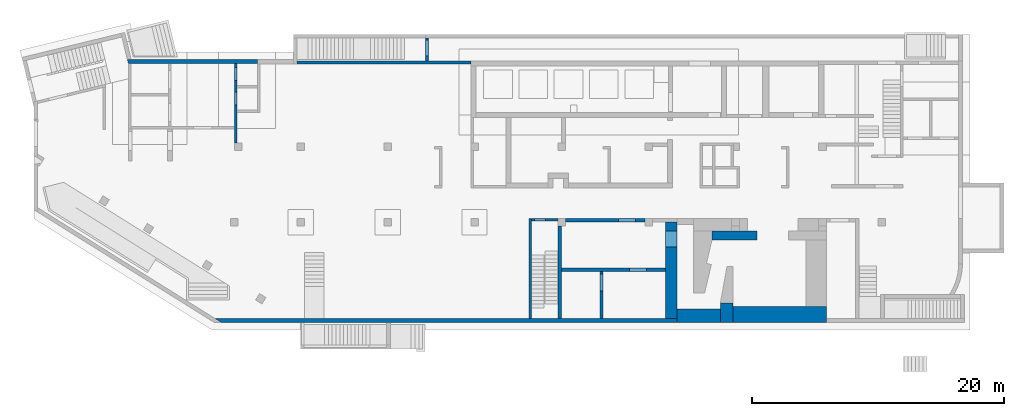
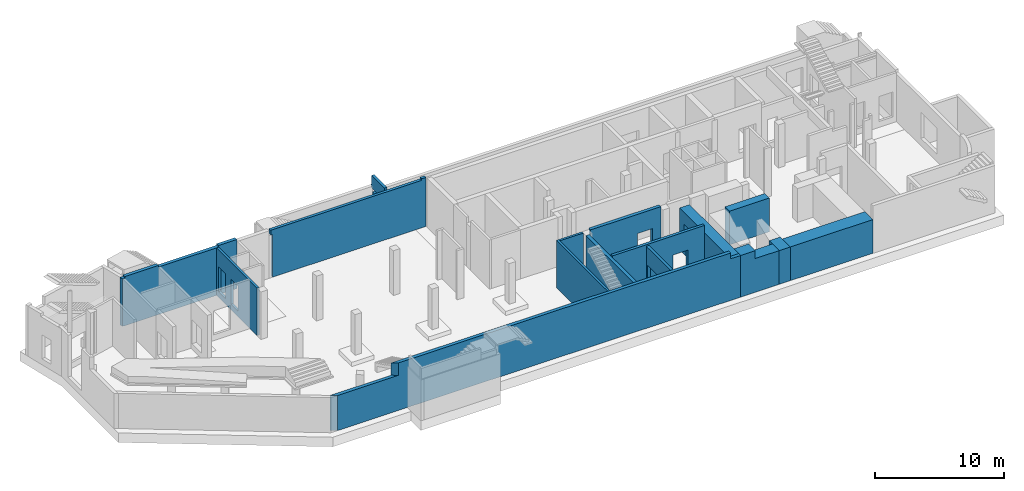
# One storey, part 6 of 9: 16 walls, 9 openings.
"""IFC4 building model written with IfcOpenShell, lengths in millimetres."""

from ifc_helpers import new_model, entity, si_unit, converted_unit, derived_unit, direction, frame, origin, place, context, subcontext, project, spatial, indexed_curve, outline, extrude, polygons, material, type_object, element, save


model = new_model("IFC4")

# Units and contexts
model_context = context("Model", 3, precision=0.01, world=origin(), true_north=direction((6.12303176911189e-17, 1.0)))
plan_context = context("Plan", 3, precision=0.01, world=origin(), true_north=direction((6.12303176911189e-17, 1.0)))
body_context = subcontext(model_context, "Body", "Model", "MODEL_VIEW")
ifc_project = project(units=[si_unit("LENGTHUNIT", "METRE", prefix="MILLI"), si_unit("AREAUNIT", "SQUARE_METRE"), si_unit("VOLUMEUNIT", "CUBIC_METRE"), converted_unit("PLANEANGLEUNIT", "DEGREE", entity("IfcRatioMeasure", 0.0174532925199433), si_unit("PLANEANGLEUNIT", "RADIAN"), dimensions=[0, 0, 0, 0, 0, 0, 0]), si_unit("MASSUNIT", "GRAM", prefix="KILO"), derived_unit("MASSDENSITYUNIT", [(si_unit("MASSUNIT", "GRAM", prefix="KILO"), 1), (si_unit("LENGTHUNIT", "METRE"), -3)]), derived_unit("MOMENTOFINERTIAUNIT", [(si_unit("LENGTHUNIT", "METRE"), 4)]), si_unit("TIMEUNIT", "SECOND"), si_unit("FREQUENCYUNIT", "HERTZ"), si_unit("THERMODYNAMICTEMPERATUREUNIT", "DEGREE_CELSIUS"), derived_unit("THERMALTRANSMITTANCEUNIT", [(si_unit("MASSUNIT", "GRAM", prefix="KILO"), 1), (si_unit("THERMODYNAMICTEMPERATUREUNIT", "KELVIN"), -1), (si_unit("TIMEUNIT", "SECOND"), -3)]), derived_unit("VOLUMETRICFLOWRATEUNIT", [(si_unit("LENGTHUNIT", "METRE"), 3), (si_unit("TIMEUNIT", "SECOND"), -1)]), derived_unit("MASSFLOWRATEUNIT", [(si_unit("MASSUNIT", "GRAM", prefix="KILO"), 1), (si_unit("TIMEUNIT", "SECOND"), -1)]), derived_unit("ROTATIONALFREQUENCYUNIT", [(si_unit("TIMEUNIT", "SECOND"), -1)]), si_unit("ELECTRICCURRENTUNIT", "AMPERE"), si_unit("ELECTRICVOLTAGEUNIT", "VOLT"), si_unit("POWERUNIT", "WATT"), si_unit("FORCEUNIT", "NEWTON", prefix="KILO"), si_unit("ILLUMINANCEUNIT", "LUX"), si_unit("LUMINOUSFLUXUNIT", "LUMEN"), si_unit("LUMINOUSINTENSITYUNIT", "CANDELA"), derived_unit("USERDEFINED", [(si_unit("MASSUNIT", "GRAM", prefix="KILO"), -1), (si_unit("LENGTHUNIT", "METRE"), -2), (si_unit("TIMEUNIT", "SECOND"), 3), (si_unit("LUMINOUSFLUXUNIT", "LUMEN"), 1)]), derived_unit("LINEARVELOCITYUNIT", [(si_unit("LENGTHUNIT", "METRE"), 1), (si_unit("TIMEUNIT", "SECOND"), -1)]), si_unit("PRESSUREUNIT", "PASCAL"), derived_unit("USERDEFINED", [(si_unit("LENGTHUNIT", "METRE"), -2), (si_unit("MASSUNIT", "GRAM", prefix="KILO"), 1), (si_unit("TIMEUNIT", "SECOND"), -2)]), derived_unit("LINEARFORCEUNIT", [(si_unit("MASSUNIT", "GRAM", prefix="KILO"), 1), (si_unit("LENGTHUNIT", "METRE"), 1), (si_unit("TIMEUNIT", "SECOND"), -2), (si_unit("LENGTHUNIT", "METRE"), -1)]), derived_unit("PLANARFORCEUNIT", [(si_unit("MASSUNIT", "GRAM", prefix="KILO"), 1), (si_unit("LENGTHUNIT", "METRE"), 1), (si_unit("TIMEUNIT", "SECOND"), -2), (si_unit("LENGTHUNIT", "METRE"), -2)])], contexts=[model_context, plan_context])

# Site, building, storey
site_placement = place(None, origin())
site = spatial("IfcSite", under=ifc_project, at=site_placement, CompositionType="ELEMENT")
building_placement = place(site_placement, origin())
building = spatial("IfcBuilding", under=site, at=building_placement, CompositionType="ELEMENT")
storey_placement = place(building_placement, frame((0.0, 0.0, -4900.0)))
storey = spatial("IfcBuildingStorey", under=building, at=storey_placement, CompositionType="ELEMENT", Elevation=-4900.0)

# Wall
ifc_material = material()
wall_type_1 = type_object("IfcWallType", PredefinedType="STANDARD")
wall_1_placement = place(storey_placement, frame((39370.0002685546, 49.9992263561803, 0.0), z_axis=(0.0, 0.0, 1.0), x_axis=(0.0, 1.0, 0.0)))
element("IfcWall", 1, at=wall_1_placement, inside=storey, type_object=wall_type_1, material=ifc_material, PredefinedType="NOTDEFINED", context=body_context, shape_type="Tessellation", body=[
    polygons([(3.8915537459161e-13, -99.9999999999945, 0.0), (7749.99999999991, -99.9999999999934, 0.0), (7949.99999999991, -99.9999999999932, 0.0), (7949.99999999991, -99.9999999999932, 4500.0), (7749.99999999991, -99.9999999999934, 4500.0), (5325.0, -99.9999999999965, 4500.0), (1.26898491714655e-13, -99.9999999999945, 4500.0), (1.91193727516747e-12, 100.000000000003, 0.0), (1.51432200112822e-12, 100.000000000003, 4500.0), (7949.99999999991, 100.000000000005, 4500.0), (7949.99999999991, 100.000000000005, 0.0)], [[[1, 2, 3, 4, 5, 6, 7]], [[8, 9, 10, 11]], [[3, 2, 1, 8, 11]], [[1, 7, 9, 8]], [[4, 3, 11, 10]], [[7, 6, 5, 4, 10, 9]]], closed=True),
])

# Wall, opening
wall_2_placement = place(storey_placement, frame((41570.0002685547, 7899.99922635609, 0.0), z_axis=(0.0, 0.0, 1.0), x_axis=(-1.0, 0.0, 0.0)))
wall_2 = element("IfcWall", 2, at=wall_2_placement, inside=storey, type_object=wall_type_1, material=ifc_material, PredefinedType="NOTDEFINED", context=body_context, shape_type="Tessellation", body=[
    polygons([(1.18902794510068e-12, -100.0, 0.0), (2100.00000000002, -100.000000000001, 0.0), (2100.00000000002, -100.000000000001, 4500.0), (1.18902794510068e-12, -100.0, 4500.0), (960.000000000008, -100.0, 2829.99999999805), (1840.00000000001, -100.000000000001, 2829.99999999804), (1840.00000000001, -100.000000000001, 550.0), (960.000000000008, -100.0, 550.0), (2100.00000000002, 99.9999999999978, 0.0), (5.09581903187964e-13, 100.0, 0.0), (5.09581903187964e-13, 100.0, 4500.0), (2100.00000000002, 99.9999999999978, 4500.0), (1840.00000000001, 99.9999999999989, 2829.99999999804), (960.000000000008, 100.000000000001, 2829.99999999805), (960.000000000008, 100.000000000001, 550.0), (1840.00000000001, 99.9999999999989, 550.0)], [[[1, 2, 3, 4], [5, 6, 7, 8]], [[9, 10, 11, 12], [13, 14, 15, 16]], [[2, 1, 10, 9]], [[4, 3, 12, 11]], [[1, 4, 11, 10]], [[3, 2, 9, 12]], [[5, 14, 13, 6]], [[6, 13, 16, 7]], [[7, 16, 15, 8]], [[14, 5, 8, 15]]], closed=True),
])
opening_1_placement = place(wall_2_placement, frame((41570.0002685547, 7899.99922635609, 0.0), z_axis=(0.0, 0.0, 1.0), x_axis=(-1.0, 0.0, 0.0)))
element("IfcOpeningElement", 3, at=opening_1_placement, cuts=wall_2, PredefinedType="OPENING", context=body_context, shape_type="SweptSolid", body=[
    extrude(outline(indexed_curve([(-439.999999999995, -1139.99999999902), (440.000000000004, -1139.99999999902), (440.000000000004, 1139.99999999902), (-439.999999999995, 1139.99999999902), (-439.999999999995, -1139.99999999902)], self_intersect=False)), frame((40170.0002685547, 8099.99922635803, 1690.0), z_axis=(0.0, -1.0, 0.0), x_axis=(-1.0, 0.0, 0.0)), (0.0, 0.0, 1.0), 400.000000001942),
])

# Wall, openings
wall_3_placement = place(storey_placement, frame((16000.0002685547, 13999.9992263563, 0.0), z_axis=(0.0, 0.0, 1.0), x_axis=(0.0, 1.0, 0.0)))
wall_3 = element("IfcWall", 4, at=wall_3_placement, inside=storey, type_object=wall_type_1, material=ifc_material, PredefinedType="NOTDEFINED", context=body_context, shape_type="Tessellation", body=[
    polygons([(0.0, -100.000000000001, 0.0), (2399.99999999961, -100.000000000001, 0.0), (2599.99999999961, -100.000000000001, 0.0), (4349.9999999998, -99.9999999999999, 0.0), (4549.9999999998, -100.000000000002, 0.0), (6300.0, -99.9999999999987, 0.0), (6300.0, -99.9999999999987, 4500.0), (2500.00063936648, -100.000000000001, 4500.0), (0.0, -100.000000000001, 4500.0), (2980.0, -100.0, 2919.99999999804), (4020.0, -100.0, 2919.99999999804), (4020.0, -100.0, 550.0), (2980.0, -100.0, 550.0), (4930.00000000001, -100.000000000001, 2919.99999999804), (5970.0, -99.9999999999992, 2919.99999999804), (5970.0, -99.9999999999992, 550.0), (4930.00000000001, -100.000000000001, 550.0), (6300.0, 99.9999999999992, 0.0), (1299.99999999955, 99.9999999999992, 0.0), (1099.99999999955, 99.9999999999989, 0.0), (0.0, 99.9999999999992, 0.0), (0.0, 99.9999999999992, 4500.0), (6300.0, 99.9999999999992, 4500.0), (4020.0, 99.9999999999996, 2919.99999999804), (2980.0, 99.9999999999978, 2919.99999999804), (2980.00000000001, 99.9999999999978, 550.0), (4020.0, 99.9999999999996, 550.0), (5970.0, 99.9999999999986, 2919.99999999804), (4930.00000000001, 99.999999999999, 2919.99999999804), (4930.00000000001, 99.999999999999, 550.0), (5970.0, 99.9999999999986, 550.0)], [[[1, 2, 3, 4, 5, 6, 7, 8, 9], [10, 11, 12, 13], [14, 15, 16, 17]], [[18, 19, 20, 21, 22, 23], [24, 25, 26, 27], [28, 29, 30, 31]], [[6, 5, 4, 3, 2, 1, 21, 20, 19, 18]], [[9, 8, 7, 23, 22]], [[1, 9, 22, 21]], [[7, 6, 18, 23]], [[24, 11, 10, 25]], [[25, 10, 13, 26]], [[26, 13, 12, 27]], [[11, 24, 27, 12]], [[28, 15, 14, 29]], [[29, 14, 17, 30]], [[30, 17, 16, 31]], [[15, 28, 31, 16]]], closed=True),
])
opening_2_placement = place(wall_3_placement, frame((-13999.9992263563, 16000.0002685547, 0.0), z_axis=(0.0, 0.0, 1.0), x_axis=(0.0, -1.0, 0.0)))
element("IfcOpeningElement", 5, at=opening_2_placement, cuts=wall_3, PredefinedType="OPENING", context=body_context, shape_type="SweptSolid", body=[
    extrude(outline(indexed_curve([(-1184.99999999902, -519.999999999999), (1184.99999999902, -519.999999999999), (1184.99999999902, 520.000000000001), (-1184.99999999902, 520.000000000001), (-1184.99999999902, -519.999999999999)], self_intersect=False)), frame((16200.0002685547, 17499.9992263564, 1735.0), z_axis=(-1.0, 0.0, 0.0), x_axis=(0.0, 0.0, -1.0)), (0.0, 0.0, 1.0), 400.000000001943),
])
opening_3_placement = place(wall_3_placement, frame((-13999.9992263563, 16000.0002685547, 0.0), z_axis=(0.0, 0.0, 1.0), x_axis=(0.0, -1.0, 0.0)))
element("IfcOpeningElement", 6, at=opening_3_placement, cuts=wall_3, PredefinedType="OPENING", context=body_context, shape_type="SweptSolid", body=[
    extrude(outline(indexed_curve([(-1184.99999999902, -519.999999999999), (1184.99999999902, -519.999999999999), (1184.99999999902, 519.999999999999), (-1184.99999999902, 519.999999999999), (-1184.99999999902, -519.999999999999)], self_intersect=False)), frame((16200.0002685547, 19449.9992263563, 1735.0), z_axis=(-1.0, 0.0, 0.0), x_axis=(0.0, 0.0, -1.0)), (0.0, 0.0, 1.0), 400.000000001943),
])

# Walls
wall_type_2 = type_object("IfcWallType", PredefinedType="STANDARD")
wall_4_placement = place(storey_placement, frame((7420.4125693099, 20449.9992263564, 0.0)))
element("IfcWall", 7, at=wall_4_placement, inside=storey, type_object=wall_type_2, material=ifc_material, PredefinedType="NOTDEFINED", context=body_context, shape_type="Tessellation", body=[
    polygons([(73.128173937497, -150.000000000005, 0.0), (79.587699244774, -150.000000000005, 0.0), (279.587699244774, -150.000000000005, 0.0), (3279.58769924477, -150.000000000005, 0.0), (3479.58769924477, -150.000000000001, 0.0), (8479.58769924478, -150.000000000001, 0.0), (8679.58769924478, -150.000000000001, 0.0), (10304.5876992448, -150.000000000005, 0.0), (10304.5876992448, -150.000000000005, 4500.0), (10304.5876992448, -150.000000000005, 4650.0), (8679.58769924479, -150.000000000001, 4650.0), (8679.58769924479, -150.000000000001, 4500.0), (8479.58769924478, -150.000000000001, 4500.0), (3479.58769924477, -150.000000000001, 4500.0), (3279.58769924479, -150.000000000005, 4500.0), (3279.58769924479, -150.000000000005, 4650.0), (279.587699244795, -150.000000000005, 4650.0), (279.587699244795, -150.000000000005, 4500.0), (79.587699244774, -150.000000000005, 4500.0), (73.1281739374959, -150.000000000005, 4500.0), (10304.5876992448, 149.999999999996, 0.0), (308.784277163578, 149.999999999996, 0.0), (2.77954970644349e-12, 150.000000000001, 0.0), (6.13815447846702e-13, 150.000000000001, 1670.0), (6.13815447846702e-13, 150.000000000001, 1870.0), (-4.69051681451691e-13, 150.000000000001, 4500.0), (279.587699244792, 149.999999999996, 4500.0), (279.587699244792, 149.999999999996, 4650.0), (3279.58769924479, 149.999999999996, 4650.0), (3279.58769924479, 149.999999999992, 4500.0), (8679.58769924478, 150.000000000001, 4500.0), (8679.58769924478, 150.000000000001, 4650.0), (10304.5876992448, 149.999999999996, 4650.0), (10304.5876992448, 149.999999999996, 4500.0), (10304.5876992448, 50.0006393664798, 4650.0)], [[[1, 2, 3, 4, 5, 6, 7, 8, 9, 10, 11, 12, 13, 14, 15, 16, 17, 18, 19, 20]], [[21, 22, 23, 24, 25, 26, 27, 28, 29, 30, 31, 32, 33, 34]], [[8, 7, 6, 5, 4, 3, 2, 1, 23, 22, 21]], [[11, 10, 35, 33, 32]], [[23, 1, 20, 26, 25, 24]], [[8, 21, 34, 33, 35, 10, 9]], [[12, 31, 30, 15, 14, 13]], [[27, 18, 17, 28]], [[15, 30, 29, 16]], [[31, 12, 11, 32]], [[18, 27, 26, 20, 19]], [[17, 16, 29, 28]]], closed=True),
])
wall_5_placement = place(storey_placement, frame((14391.9394845148, -100.000773643646, 0.0)))
element("IfcWall", 8, at=wall_5_placement, inside=storey, type_object=wall_type_2, material=ifc_material, PredefinedType="NOTDEFINED", context=body_context, shape_type="Tessellation", body=[
    polygons([(480.109728548428, -150.0, 0.0), (6748.06078403981, -150.0, 0.0), (7048.06078403981, -150.0, 0.0), (13598.0607840398, -150.0, 0.0), (13898.0607840398, -150.0, 0.0), (36628.0607840398, -150.0, 0.0), (36628.0607840398, -150.000000000014, 3950.0), (35728.0607840398, -150.0, 3950.0), (35728.0607840398, -150.0, 4500.0), (27178.0607840398, -150.0, 4500.0), (25078.0607840398, -150.000000000001, 4500.0), (5952.71829370465, -150.000000000001, 4500.0), (5952.71829370465, -150.000000000002, 3580.0), (5952.71829370465, -150.000000000001, 3330.0), (480.109728548424, -150.0, 3330.0), (-2.51150603102073e-12, 150.0, 0.0), (6.15143100336641e-12, 150.000000000001, 3330.0), (5472.60856515624, 149.999999999999, 3330.0), (5472.60856515624, 149.999999999999, 4500.0), (6793.58304640091, 150.0, 4500.0), (24878.0607840398, 150.0, 4500.0), (25078.0607840398, 150.0, 4500.0), (27178.0607840398, 150.0, 4500.0), (27478.0607840398, 150.0, 4500.0), (30508.0607840398, 150.0, 4500.0), (30758.0607840398, 150.0, 4500.0), (35728.0607840398, 150.0, 4500.0), (35728.0607840398, 150.0, 3950.0), (36628.0607840398, 150.0, 3950.0), (36628.0607840398, 150.0, 0.0), (35728.0607840398, 150.0, 0.0), (30758.0607840398, 150.0, 0.0), (30508.0607840398, 150.0, 0.0), (27478.0607840398, 150.0, 0.0), (27178.0607840398, 150.0, 0.0), (25078.0607840398, 150.0, 0.0), (24878.0607840398, 150.0, 0.0)], [[[1, 2, 3, 4, 5, 6, 7, 8, 9, 10, 11, 12, 13, 14, 15]], [[16, 17, 18, 19, 20, 21, 22, 23, 24, 25, 26, 27, 28, 29, 30, 31, 32, 33, 34, 35, 36, 37]], [[6, 5, 4, 3, 2, 1, 16, 37, 36, 35, 34, 33, 32, 31, 30]], [[1, 15, 17, 16]], [[7, 6, 30, 29]], [[11, 10, 23, 22]], [[12, 19, 18, 14, 13]], [[27, 9, 8, 28]], [[10, 9, 27, 26, 25, 24, 23]], [[12, 11, 22, 21, 20, 19]], [[15, 14, 18, 17]], [[8, 7, 29, 28]]], closed=True),
])
wall_6_placement = place(storey_placement, frame((41720.0002685546, 49.9992263561641, 0.0), z_axis=(0.0, 0.0, 1.0), x_axis=(0.0, 1.0, 0.0)))
element("IfcWall", 9, at=wall_6_placement, inside=storey, type_object=wall_type_2, material=ifc_material, PredefinedType="NOTDEFINED", context=body_context, shape_type="Tessellation", body=[
    polygons([(3.38395977905748e-14, -150.000000000001, 0.0), (3749.99999999999, -150.000000000005, 0.0), (3999.99999999999, -150.000000000004, 0.0), (7349.99999999992, -150.000000000001, 0.0), (7349.99999999992, -150.000000000001, 4500.0), (8.45989944764369e-15, -150.000000000001, 4500.0), (1.81887838124339e-12, 150.000000000001, 0.0), (1.75965908510989e-12, 150.000000000001, 4500.0), (5325.00000000001, 149.999999999998, 4500.0), (7349.99999999992, 150.000000000001, 4500.0), (7349.99999999992, 150.000000000001, 0.0)], [[[1, 2, 3, 4, 5, 6]], [[7, 8, 9, 10, 11]], [[4, 3, 2, 1, 7, 11]], [[5, 4, 11, 10]], [[1, 6, 8, 7]], [[6, 5, 10, 9, 8]]], closed=True),
])

# Wall, opening
wall_7_placement = place(storey_placement, frame((42170.0002685547, 7849.99922635609, 0.0)))
wall_7 = element("IfcWall", 10, at=wall_7_placement, inside=storey, type_object=wall_type_2, material=ifc_material, PredefinedType="NOTDEFINED", context=body_context, shape_type="Tessellation", body=[
    polygons([(8.42232516012628e-13, -149.999999999999, 0.0), (6299.99999999999, -149.999999999999, 0.0), (6299.99999999999, -149.999999999999, 4650.0), (8.42232516012628e-13, -149.999999999999, 4650.0), (4199.99999999998, -149.999999999998, 2829.99999999805), (5549.99999999999, -149.999999999998, 2829.99999999804), (5549.99999999999, -149.999999999998, 550.0), (4199.99999999998, -149.999999999998, 550.0), (6299.99999999999, 150.000000000001, 0.0), (-1.37504410495438e-13, 149.999999999999, 0.0), (-1.37504410495442e-13, 150.000000000001, 4500.0), (-1.37504410495438e-13, 149.999999999999, 4650.0), (6299.99999999999, 150.000000000001, 4650.0), (6299.99999999999, 150.000000000001, 4500.0), (5549.99999999999, 150.000000000001, 2829.99999999804), (4199.99999999998, 150.000000000001, 2829.99999999805), (4199.99999999998, 150.000000000001, 550.0), (5549.99999999999, 150.000000000001, 550.0)], [[[1, 2, 3, 4], [5, 6, 7, 8]], [[9, 10, 11, 12, 13, 14], [15, 16, 17, 18]], [[2, 1, 10, 9]], [[3, 2, 9, 14, 13]], [[4, 3, 13, 12]], [[1, 4, 12, 11, 10]], [[5, 16, 15, 6]], [[6, 15, 18, 7]], [[7, 18, 17, 8]], [[16, 5, 8, 17]]], closed=True),
])
opening_4_placement = place(wall_7_placement, frame((-42170.0002685547, -7849.99922635609, 0.0)))
element("IfcOpeningElement", 11, at=opening_4_placement, cuts=wall_7, PredefinedType="OPENING", context=body_context, shape_type="SweptSolid", body=[
    extrude(outline(indexed_curve([(-675.000000000003, -1139.99999999902), (674.999999999994, -1139.99999999902), (674.999999999994, 1139.99999999902), (-675.000000000003, 1139.99999999902), (-675.000000000003, -1139.99999999902)], self_intersect=False)), frame((47045.0002685547, 7599.99922635413, 1690.0), z_axis=(0.0, 1.0, 0.0), x_axis=(1.0, 0.0, 0.0)), (0.0, 0.0, 1.0), 500.000000001943),
])

# Wall
wall_type_3 = type_object("IfcWallType", PredefinedType="STANDARD")
wall_8_placement = place(storey_placement, frame((53803.2375853265, 6649.99922635606, 0.0)))
element("IfcWall", 12, at=wall_8_placement, inside=storey, type_object=wall_type_3, material=ifc_material, PredefinedType="NOTDEFINED", context=body_context, shape_type="Tessellation", body=[
    polygons([(1.11788315284292e-13, -349.999999999999, 0.0), (3566.7626832281, -349.999999999999, 0.0), (3566.7626832281, -349.999999999999, 3200.0), (1.11788315284292e-13, -349.999999999999, 3200.0), (-1.8008881144258e-12, 350.000000000002, 0.0), (-1.80088811442579e-12, 350.000000000001, 3000.0), (-1.8008881144258e-12, 350.000000000002, 3200.0), (2166.76268322811, 349.999999999999, 3200.0), (2816.76268322809, 350.000000000001, 3200.0), (3566.76268322809, 350.000000000001, 3200.0), (3566.76268322809, 350.000000000001, 0.0), (2816.76268322809, 350.000000000001, 0.0), (2166.76268322811, 349.999999999999, 0.0), (1566.76268322811, 350.000000000001, 0.0)], [[[1, 2, 3, 4]], [[5, 6, 7, 8, 9, 10, 11, 12, 13, 14]], [[2, 1, 5, 14, 13, 12, 11]], [[3, 2, 11, 10]], [[1, 4, 7, 6, 5]], [[4, 3, 10, 9, 8, 7]]], closed=True),
])

# Wall, opening
wall_type_4 = type_object("IfcWallType", PredefinedType="STANDARD")
wall_9_placement = place(storey_placement, frame((41870.0002685546, 3924.99922635616, 0.0)))
wall_9 = element("IfcWall", 13, at=wall_9_placement, inside=storey, type_object=wall_type_4, material=ifc_material, PredefinedType="NOTDEFINED", context=body_context, shape_type="Tessellation", body=[
    polygons([(-3.3681141022685e-12, -125.0, 0.0), (3029.99999999998, -125.0, 0.0), (3279.99999999999, -125.0, 0.0), (8249.99999999999, -125.0, 0.0), (8249.99999999999, -125.0, 4650.0), (-3.3681141022685e-12, -125.0, 4650.0), (5399.99999999998, -125.000000000001, 2829.99999999804), (6749.99999999999, -125.000000000001, 2829.99999999805), (6749.99999999999, -125.000000000001, 550.0), (5399.99999999998, -125.000000000001, 550.0), (8249.99999999999, 124.999999999999, 0.0), (-4.15963078556216e-12, 124.999999999999, 0.0), (-4.15963078556216e-12, 124.999999999999, 4650.0), (8249.99999999999, 124.999999999999, 4650.0), (6749.99999999999, 125.0, 2829.99999999805), (5399.99999999998, 125.0, 2829.99999999804), (5399.99999999998, 125.0, 550.0), (6749.99999999999, 125.0, 550.0)], [[[1, 2, 3, 4, 5, 6], [7, 8, 9, 10]], [[11, 12, 13, 14], [15, 16, 17, 18]], [[4, 3, 2, 1, 12, 11]], [[6, 5, 14, 13]], [[1, 6, 13, 12]], [[5, 4, 11, 14]], [[15, 8, 7, 16]], [[16, 7, 10, 17]], [[17, 10, 9, 18]], [[8, 15, 18, 9]]], closed=True),
])
opening_5_placement = place(wall_9_placement, frame((-41870.0002685546, -3924.99922635616, 0.0)))
element("IfcOpeningElement", 14, at=opening_5_placement, cuts=wall_9, PredefinedType="OPENING", context=body_context, shape_type="SweptSolid", body=[
    extrude(outline(indexed_curve([(-1139.99999999902, -674.999999999994), (1139.99999999902, -674.999999999994), (1139.99999999902, 675.000000000003), (-1139.99999999902, 675.000000000003), (-1139.99999999902, -674.999999999994)], self_intersect=False)), frame((47945.0002685546, 3699.99922635614, 1690.0), z_axis=(0.0, 1.0, 0.0), x_axis=(0.0, 0.0, -1.0)), (0.0, 0.0, 1.0), 450.000000000965),
])

wall_10_placement = place(storey_placement, frame((45025.0002685546, 3799.99922635615, 0.0), z_axis=(0.0, 0.0, 1.0), x_axis=(0.0, -1.0, 0.0)))
wall_10 = element("IfcWall", 15, at=wall_10_placement, inside=storey, type_object=wall_type_4, material=ifc_material, PredefinedType="NOTDEFINED", context=body_context, shape_type="Tessellation", body=[
    polygons([(0.0, -125.000000000007, 0.0), (3750.00000000001, -125.000000000006, 0.0), (3750.00000000001, -125.000000000006, 4500.0), (0.0, -125.000000000007, 4500.0), (200.0, -125.000000000007, 2829.99999999804), (1550.0, -125.000000000003, 2829.99999999805), (1550.0, -125.000000000003, 550.0), (200.000000000001, -125.000000000007, 550.0), (3750.00000000001, 124.999999999997, 0.0), (-5.41433564649196e-13, 124.999999999996, 0.0), (-5.41433564649196e-13, 124.999999999996, 4500.0), (3750.00000000001, 124.999999999997, 4500.0), (1550.0, 125.0, 2829.99999999805), (200.000000000001, 124.999999999997, 2829.99999999804), (200.000000000001, 124.999999999997, 550.0), (1550.0, 125.0, 550.0)], [[[1, 2, 3, 4], [5, 6, 7, 8]], [[9, 10, 11, 12], [13, 14, 15, 16]], [[2, 1, 10, 9]], [[3, 2, 9, 12]], [[1, 4, 11, 10]], [[4, 3, 12, 11]], [[13, 6, 5, 14]], [[14, 5, 8, 15]], [[15, 8, 7, 16]], [[6, 13, 16, 7]]], closed=True),
])
opening_6_placement = place(wall_10_placement, frame((3799.99922635615, -45025.0002685546, 0.0), z_axis=(0.0, 0.0, 1.0), x_axis=(0.0, 1.0, 0.0)))
element("IfcOpeningElement", 16, at=opening_6_placement, cuts=wall_10, PredefinedType="OPENING", context=body_context, shape_type="SweptSolid", body=[
    extrude(outline(indexed_curve([(-1139.99999999902, -675.0), (1139.99999999902, -675.0), (1139.99999999902, 675.0), (-1139.99999999902, 675.0), (-1139.99999999902, -675.0)], self_intersect=False)), frame((44800.0002685546, 2924.99922635615, 1690.0), z_axis=(1.0, 0.0, 0.0), x_axis=(0.0, 0.0, -1.0)), (0.0, 0.0, 1.0), 450.000000000963),
])

# Wall
wall_11_placement = place(storey_placement, frame((34670.0002685547, 20374.9992263561, 0.0), z_axis=(0.0, 0.0, 1.0), x_axis=(-1.0, 0.0, 0.0)))
element("IfcWall", 17, at=wall_11_placement, inside=storey, type_object=wall_type_4, material=ifc_material, PredefinedType="NOTDEFINED", context=body_context, shape_type="Tessellation", body=[
    polygons([(-5.34363569620451e-13, -124.999999999998, 0.0), (3360.0, -124.999999999998, 0.0), (3610.0, -125.000000000002, 0.0), (13780.0, -124.999999999998, 0.0), (13780.0, -124.999999999998, 4035.0), (13930.0, -124.999999999998, 4035.0), (13930.0, -124.999999999998, 4500.0), (399.999999999952, -125.000213122213, 4500.0), (399.999999999952, -124.999999999998, 4650.0), (-5.34363569620451e-13, -124.999999999998, 4650.0), (-5.34363569620451e-13, -124.999999999998, 4450.0), (13780.0, 125.000000000002, 0.0), (-1.32018877230434e-12, 125.000000000002, 0.0), (-1.32018877230434e-12, 125.000000000002, 4650.0), (399.999999999951, 125.000000000002, 4650.0), (399.999999999951, 125.000000000002, 4500.0), (13930.0, 125.000000000002, 4500.0), (13930.0, 125.000000000002, 4035.0), (13780.0, 125.000000000002, 4035.0)], [[[1, 2, 3, 4, 5, 6, 7, 8, 9, 10, 11]], [[12, 13, 14, 15, 16, 17, 18, 19]], [[4, 3, 2, 1, 13, 12]], [[14, 10, 9, 15]], [[1, 11, 10, 14, 13]], [[6, 18, 17, 7]], [[18, 6, 5, 19]], [[4, 12, 19, 5]], [[16, 8, 7, 17]], [[8, 16, 15, 9]]], closed=True),
])

# Wall, openings
wall_12_placement = place(storey_placement, frame((31185.0002685547, 20499.9992263561, 0.0), z_axis=(0.0, 0.0, 1.0), x_axis=(0.0, 1.0, 0.0)))
wall_12 = element("IfcWall", 18, at=wall_12_placement, inside=storey, type_object=wall_type_4, material=ifc_material, PredefinedType="NOTDEFINED", context=body_context, shape_type="Tessellation", body=[
    polygons([(0.0, -124.999999999996, 0.0), (1799.99999999994, -124.999999999992, 0.0), (1799.99999999994, -124.999999999992, 3300.0), (0.0, -124.999999999996, 3300.0), (399.999999999939, -124.999999999995, 2829.99999999805), (1649.99999999994, -124.999999999992, 2829.99999999804), (1649.99999999994, -124.999999999992, 550.0), (399.999999999939, -124.999999999995, 550.0), (1799.99999999994, 125.000000000004, 0.0), (4.33146851719357e-12, 125.000000000004, 0.0), (4.33146851719357e-12, 125.000000000004, 3300.0), (1799.99999999994, 125.000000000008, 3300.0), (1649.99999999994, 125.000000000003, 2829.99999999804), (399.999999999939, 125.000000000005, 2829.99999999805), (399.999999999939, 125.000000000005, 550.0), (1649.99999999994, 125.000000000003, 550.0)], [[[1, 2, 3, 4], [5, 6, 7, 8]], [[9, 10, 11, 12], [13, 14, 15, 16]], [[2, 1, 10, 9]], [[10, 1, 4, 11]], [[2, 9, 12, 3]], [[4, 3, 12, 11]], [[5, 14, 13, 6]], [[16, 7, 6, 13]], [[7, 16, 15, 8]], [[8, 15, 14, 5]]], closed=True),
    polygons([(0.0, -124.999999999996, 4725.0), (1999.99999999993, -124.999999999991, 4725.0), (1999.99999999993, 125.000000000004, 4725.0), (1799.99999999993, 125.000000000004, 4725.0), (4.33146851719357e-12, 125.000000000004, 4725.0), (2099.99999999994, -125.0, 3550.0), (0.0, -124.999999999996, 3550.0), (4.33146851719357e-12, 125.000000000004, 3550.0), (2099.99999999994, 125.000000000009, 3550.0), (1999.99999999993, -124.999999999991, 3825.0), (2099.99999999994, -125.0, 3825.0), (2099.99999999994, 125.000000000004, 3825.0), (1999.99999999993, 125.000000000004, 3825.0)], [[[1, 2, 3, 4, 5]], [[6, 7, 8, 9]], [[10, 11, 12, 13]], [[12, 11, 6, 9]], [[3, 2, 10, 13]], [[1, 5, 8, 7]], [[5, 4, 3, 13, 12, 9, 8]], [[2, 1, 7, 6, 11, 10]]], closed=True),
])
opening_7_placement = place(storey_placement, frame((31185.0002685547, 20499.9992263561, 0.0), z_axis=(0.0, 0.0, 1.0), x_axis=(0.0, 1.0, 0.0)))
element("IfcOpeningElement", 19, at=opening_7_placement, cuts=wall_12, PredefinedType="OPENING", context=body_context, shape_type="SweptSolid", body=[
    extrude(outline(indexed_curve([(-899.999999999968, -125.0), (899.999999999969, -125.0), (899.999999999968, 125.000000000004), (-899.999999999965, 125.0), (-899.999999999968, -125.0)], self_intersect=False)), frame((900.0, 0.0, 3300.0)), (0.0, 0.0, 1.0), 250.0),
])
opening_8_placement = place(wall_12_placement, frame((-20499.9992263561, 31185.0002685547, 0.0), z_axis=(0.0, 0.0, 1.0), x_axis=(0.0, -1.0, 0.0)))
element("IfcOpeningElement", 20, at=opening_8_placement, cuts=wall_12, PredefinedType="OPENING", context=body_context, shape_type="SweptSolid", body=[
    extrude(outline(indexed_curve([(-625.000000000001, -1139.99999999902), (625.000000000001, -1139.99999999902), (625.000000000001, 1139.99999999902), (-625.000000000001, 1139.99999999902), (-625.000000000001, -1139.99999999902)], self_intersect=False)), frame((31410.0002685556, 21524.9992263561, 1690.0), z_axis=(-1.0, 0.0, 0.0), x_axis=(0.0, 1.0, 0.0)), (0.0, 0.0, 1.0), 450.000000000968),
])

# Wall, opening
wall_type_5 = type_object("IfcWallType", PredefinedType="STANDARD")
wall_13_placement = place(storey_placement, frame((50570.0002685546, 49.9992263561014, 0.0), z_axis=(0.0, 0.0, 1.0), x_axis=(0.0, 1.0, 0.0)))
wall_13 = element("IfcWall", 21, at=wall_13_placement, inside=storey, type_object=wall_type_5, material=ifc_material, PredefinedType="NOTDEFINED", context=body_context, shape_type="Tessellation", body=[
    polygons([(0.0, -450.000000000002, 0.0), (750.0, -450.0, 0.0), (7449.99999999995, -449.999999999999, 0.0), (7649.99999999996, -449.999999999998, 0.0), (7649.99999999996, -449.999999999998, 3950.0), (7449.99999999996, -449.999999999999, 3950.0), (750.0, -450.0, 3950.0), (2.96096480667529e-13, -450.000000000002, 3950.0), (5699.99999999996, -450.000000000001, 2829.99999999805), (6949.99999999996, -449.999999999999, 2829.99999999804), (6949.99999999996, -449.999999999999, 550.0), (5699.99999999996, -450.000000000001, 550.0), (7649.99999999996, 450.000000000005, 0.0), (4000.00000000003, 449.999999999999, 0.0), (3750.00000000003, 449.999999999999, 0.0), (4.46682690835587e-12, 450.000000000002, 0.0), (4.83906248405219e-12, 450.000000000002, 3950.0), (7649.99999999996, 450.000000000005, 3950.0), (6949.99999999996, 450.000000000004, 2829.99999999804), (5699.99999999996, 450.000000000002, 2829.99999999805), (5699.99999999996, 450.000000000002, 550.0), (6949.99999999996, 450.000000000004, 550.0), (7649.99999999996, 3.26519321837455e-12, 3950.0)], [[[1, 2, 3, 4, 5, 6, 7, 8], [9, 10, 11, 12]], [[13, 14, 15, 16, 17, 18], [19, 20, 21, 22]], [[4, 3, 2, 1, 16, 15, 14, 13]], [[5, 4, 13, 18, 23]], [[1, 8, 17, 16]], [[8, 7, 6, 5, 23, 18, 17]], [[9, 20, 19, 10]], [[10, 19, 22, 11]], [[11, 22, 21, 12]], [[20, 9, 12, 21]]], closed=True),
])
opening_9_placement = place(wall_13_placement, frame((-49.9992263561014, 50570.0002685546, 0.0), z_axis=(0.0, 0.0, 1.0), x_axis=(0.0, -1.0, 0.0)))
element("IfcOpeningElement", 22, at=opening_9_placement, cuts=wall_13, PredefinedType="OPENING", context=body_context, shape_type="SweptSolid", body=[
    extrude(outline(indexed_curve([(-625.0, -1139.99999999902), (625.0, -1139.99999999902), (625.0, 1139.99999999902), (-625.0, 1139.99999999902), (-625.0, -1139.99999999902)], self_intersect=False)), frame((51120.0002685566, 6374.99922635606, 1690.0), z_axis=(-1.0, 0.0, 0.0), x_axis=(0.0, 1.0, 0.0)), (0.0, 0.0, 1.0), 1100.00000000194),
])

# Walls
wall_type_6 = type_object("IfcWallType", PredefinedType="STANDARD")
wall_14_placement = place(storey_placement, frame((51020.0002685546, 274.999226356101, 0.0)))
element("IfcWall", 23, at=wall_14_placement, inside=storey, type_object=wall_type_6, material=ifc_material, PredefinedType="NOTDEFINED", context=body_context, shape_type="Tessellation", body=[
    polygons([(1.70390577124004e-12, -525.0, 0.0), (3450.0, -525.0, 0.0), (3450.0, -525.000000000011, 3200.0), (1300.0, -525.0, 3200.0), (1300.0, -525.0, 3950.0), (1.70390577124004e-12, -525.0, 3950.0), (-5.45247632200275e-12, 525.0, 0.0), (-5.45247632200275e-12, 525.0, 3950.0), (1299.99999999999, 525.0, 3950.0), (1299.99999999999, 525.0, 3200.0), (3449.99999999999, 525.0, 3200.0), (3449.99999999999, 525.0, 0.0), (-3.40774826829325e-13, -225.0, 0.0), (-3.40774826829325e-13, -225.0, 3950.0)], [[[1, 2, 3, 4, 5, 6]], [[7, 8, 9, 10, 11, 12]], [[2, 1, 13, 7, 12]], [[1, 6, 14, 8, 7, 13]], [[3, 2, 12, 11]], [[6, 5, 9, 8, 14]], [[9, 5, 4, 10]], [[4, 3, 11, 10]]], closed=True),
])
wall_type_7 = type_object("IfcWallType", PredefinedType="STANDARD")
wall_15_placement = place(storey_placement, frame((55470.0002685546, 374.99922635607, 0.0)))
element("IfcWall", 24, at=wall_15_placement, inside=storey, type_object=wall_type_7, material=ifc_material, PredefinedType="NOTDEFINED", context=body_context, shape_type="Tessellation", body=[
    polygons([(1.03859299249257e-11, -625.0, 0.0), (7400.00000000002, -625.0, 0.0), (7400.00000000002, -625.0, 3200.0), (1.03859299249257e-11, -625.0, 3200.0), (1.77099213181024e-12, 625.0, 0.0), (1.77099213181024e-12, 625.0, 3200.0), (5800.00000000001, 625.0, 3200.0), (7400.00000000002, 625.0, 3200.0), (7400.00000000001, 625.0, 0.0), (5800.00000000001, 625.0, 0.0), (7400.00000000002, -325.0, 0.0)], [[[1, 2, 3, 4]], [[5, 6, 7, 8, 9, 10]], [[2, 1, 5, 10, 9, 11]], [[1, 4, 6, 5]], [[3, 2, 11, 9, 8]], [[4, 3, 8, 7, 6]]], closed=True),
])
wall_type_8 = type_object("IfcWallType", PredefinedType="STANDARD")
wall_16_placement = place(storey_placement, frame((54970.0002685546, -250.000773643959, 0.0), z_axis=(0.0, 0.0, 1.0), x_axis=(0.0, 1.0, 0.0)))
element("IfcWall", 25, at=wall_16_placement, inside=storey, type_object=wall_type_8, material=ifc_material, PredefinedType="NOTDEFINED", context=body_context, shape_type="Tessellation", body=[
    polygons([(2.97788460557058e-11, -499.999999999999, 0.0), (1250.00000000003, -499.999999999999, 0.0), (1550.00000000004, -499.999999999999, 0.0), (1550.00000000004, -499.999999999999, 3200.0), (1250.00000000003, -499.999999999999, 3200.0), (9.91500215263841e-12, -499.999999999999, 3200.0), (3.66821240049831e-11, 499.999999999999, 0.0), (3.65806052116113e-11, 499.999999999999, 3200.0), (1050.00000000004, 499.999999999999, 3200.0), (1550.00000000004, 499.999999999999, 3200.0), (1550.00000000004, 499.999999999999, 0.0), (1050.00000000004, 499.999999999999, 0.0)], [[[1, 2, 3, 4, 5, 6]], [[7, 8, 9, 10, 11, 12]], [[3, 2, 1, 7, 12, 11]], [[4, 3, 11, 10]], [[1, 6, 8, 7]], [[6, 5, 4, 10, 9, 8]]], closed=True),
])

save(model, "model.ifc")
